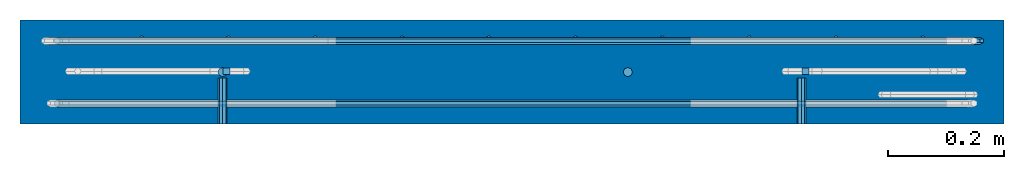
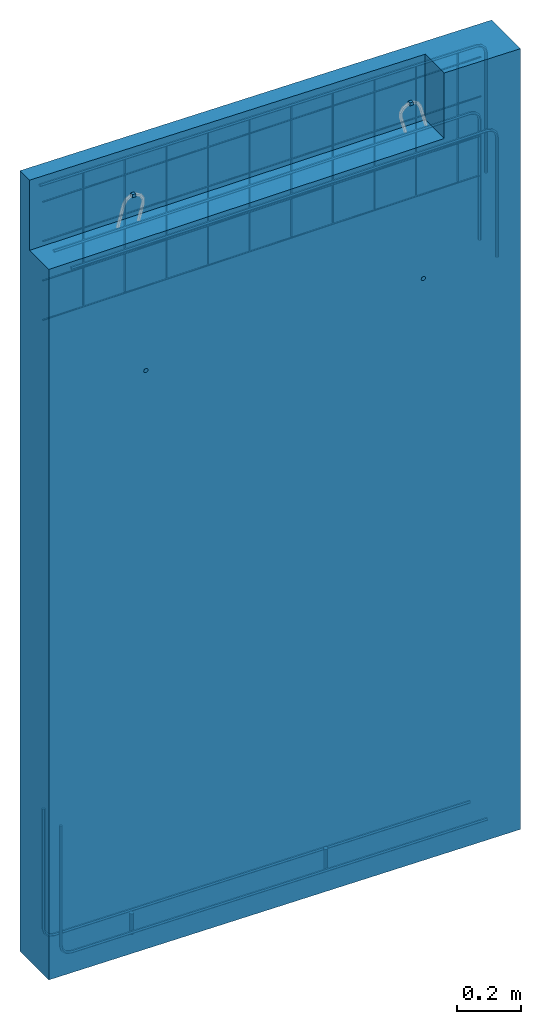
# One storey, part 1 of 3: 6 beams, 4 reinforcing bars, 1 wall.
"""IFC2X3 building model written with IfcOpenShell, lengths in millimetres."""

from ifc_helpers import new_model, si_unit, frame, origin_with_axes, place, context, subcontext, project, spatial, faceted_brep, source, transform, mapped, material, type_object, element, save


model = new_model("IFC2X3")

# Units and contexts
model_context = context("Model", 3, precision=1e-05, world=origin_with_axes())
body_context = subcontext(model_context, "Body", "Model", "MODEL_VIEW")
ifc_project = project(units=[si_unit("LENGTHUNIT", "METRE", prefix="MILLI"), si_unit("AREAUNIT", "SQUARE_METRE"), si_unit("VOLUMEUNIT", "CUBIC_METRE"), si_unit("MASSUNIT", "GRAM", prefix="KILO"), si_unit("TIMEUNIT", "SECOND"), si_unit("PLANEANGLEUNIT", "RADIAN"), si_unit("SOLIDANGLEUNIT", "STERADIAN"), si_unit("THERMODYNAMICTEMPERATUREUNIT", "DEGREE_CELSIUS"), si_unit("LUMINOUSINTENSITYUNIT", "LUMEN")], contexts=[model_context])

# Site, building, storey
site_placement = place(None, origin_with_axes())
site = spatial("IfcSite", under=ifc_project, at=site_placement, CompositionType="ELEMENT")
building_placement = place(site_placement, origin_with_axes())
building = spatial("IfcBuilding", under=site, at=building_placement, Name="Undefined", CompositionType="ELEMENT")
storey_placement = place(building_placement, origin_with_axes())
storey = spatial("IfcBuildingStorey", under=building, at=storey_placement, Name="Undefined", CompositionType="ELEMENT", Elevation=0.0)

# Beams
ifc_material_1 = material(Name="STEEL/Steel_Undefined")
beam_type_1 = type_object("IfcBeamType", Name="D16", PredefinedType="NOTDEFINED")
for number, where, z_axis, x_axis, name in (
    (1, (350.057217246016, 0.0346569152604559, -2.46430431616318e-06), (-1.9400001925155e-05, -0.99999999923382, -3.40000033739502e-05), (2.84000028124163e-05, -3.40000033666368e-05, 0.99999999901872), "M16"),
    (2, (1050.08669594096, 0.0127059129733595, 0.748830884854215), (-1.9400001925155e-05, -0.99999999923382, -3.40000033739502e-05), (2.84000028124163e-05, -3.40000033666368e-05, 0.99999999901872), "M16"),
):
    element("IfcBeam", number, at=place(storey_placement, frame(where, z_axis=z_axis, x_axis=x_axis)), inside=storey, type_object=beam_type_1, material=ifc_material_1, Name=name, ObjectType="D16", context=body_context, shape_type="Brep", body=[
        faceted_brep([(0.0, -8.0, 0.0), (-3.11670103440853e-09, -5.65685424949237, -5.65685424949238), (79.9999128622613, -5.65685424949231, -5.65685424949238), (79.999912865378, -8.0, 0.0), (-4.40768087132948e-09, 0.0, -8.0), (79.9999128609703, 0.0, -8.0), (-3.11670103614325e-09, 5.65685424949237, -5.65685424949238), (79.9999128622613, 5.65685424949237, -5.65685424949238), (1.73472347597681e-18, 7.99999999999994, 9.78384040450919e-16), (79.999912865378, 7.99999999999994, 9.78384040450919e-16), (3.11670103614325e-09, 5.65685424949237, 5.65685424949238), (79.9999128684947, 5.65685424949237, 5.65685424949238), (4.40768087479892e-09, 0.0, 8.0), (79.9999128697857, -5.6843418860808e-14, 8.0), (3.11670103787798e-09, -5.65685424949243, 5.65685424949238), (79.9999128684947, -5.65685424949237, 5.65685424949238)], [[[0, 1, 2, 3]], [[1, 4, 5, 2]], [[4, 6, 7, 5]], [[6, 8, 9, 7]], [[8, 10, 11, 9]], [[10, 12, 13, 11]], [[12, 14, 15, 13]], [[14, 0, 3, 15]], [[5, 7, 9, 11, 13, 15, 3, 2]], [[14, 12, 10, 8, 6, 4, 1, 0]]]),
    ])
for number, where, z_axis, x_axis, name in (
    (3, (349.999999989523, -89.9999999965587, 2199.99999753579), (0.0, 0.0, 1.0), (0.0, 1.0, 0.0), "M16"),
    (4, (1349.99975334186, -89.9999999756695, 2199.99999753581), (0.0, 0.0, 1.0), (0.0, 1.0, 0.0), "M16"),
):
    element("IfcBeam", number, at=place(storey_placement, frame(where, z_axis=z_axis, x_axis=x_axis)), inside=storey, type_object=beam_type_1, material=ifc_material_1, Name=name, ObjectType="D16", context=body_context, shape_type="Brep", body=[
        faceted_brep([(0.0, -8.0, 0.0), (-3.11670103440853e-09, -5.65685424949237, -5.65685424949238), (79.9999858370938, -5.65685424949237, -5.65685424949243), (79.9999858370938, -8.0, 0.0), (-4.40768087132948e-09, 0.0, -8.0), (79.9999858370938, 0.0, -8.0), (-3.11670103614325e-09, 5.65685424949237, -5.65685424949238), (79.9999858370938, 5.65685424949237, -5.65685424949243), (1.73472347597681e-18, 7.99999999999994, 9.78384040450919e-16), (79.9999858370938, 8.0, 0.0), (3.11670103614325e-09, 5.65685424949237, 5.65685424949238), (79.9999858370938, 5.65685424949237, 5.65685424949243), (4.40768087479892e-09, 0.0, 8.0), (79.9999858370938, 0.0, 8.0), (3.11670103787798e-09, -5.65685424949243, 5.65685424949238), (79.9999858370938, -5.65685424949237, 5.65685424949243)], [[[0, 1, 2, 3]], [[1, 4, 5, 2]], [[4, 6, 7, 5]], [[6, 8, 9, 7]], [[8, 10, 11, 9]], [[10, 12, 13, 11]], [[12, 14, 15, 13]], [[14, 0, 3, 15]], [[5, 7, 9, 11, 13, 15, 3, 2]], [[14, 12, 10, 8, 6, 4, 1, 0]]]),
    ])
ifc_material_2 = material()
beam_type_2 = type_object("IfcBeamType", PredefinedType="NOTDEFINED")
for number, where, z_axis, x_axis in (
    (5, (350.847429017407, 1.45757086954141, 2811.46999823785), (0.0, 0.0, 1.0), (1.0, 0.0, 0.0)),
    (6, (1362.84742901741, 1.45757086954141, 2811.46999823785), (0.0, 0.0, 1.0), (-1.0, 0.0, 0.0)),
):
    element("IfcBeam", number, at=place(storey_placement, frame(where, z_axis=z_axis, x_axis=x_axis)), inside=storey, type_object=beam_type_2, material=ifc_material_2, context=body_context, shape_type="Brep", body=[
        faceted_brep([(0.0, 6.0, -6.0), (0.0, 6.0, 6.0), (12.0, 6.0, 6.0), (12.0, 6.0, -6.0), (0.0, -6.0, 6.0), (12.0, -6.0, 6.0), (0.0, -6.0, -6.0), (12.0, -6.0, -6.0)], [[[0, 1, 2, 3]], [[1, 4, 5, 2]], [[4, 6, 7, 5]], [[6, 0, 3, 7]], [[5, 7, 3, 2]], [[6, 4, 1, 0]]]),
    ])

# Wall
ifc_material_3 = material(Name="CONCRETE/C30/37")
wall_type = type_object("IfcWallType", PredefinedType="NOTDEFINED")
wall_placement = place(storey_placement, frame((-9.94113120001435e-09, -2.55795838746404e-13, 1524.96999823788), z_axis=(0.0, 0.0, 1.0), x_axis=(1.0, 0.0, 0.0)))
element("IfcWall", 7, at=wall_placement, inside=storey, type_object=wall_type, material=ifc_material_3, context=body_context, shape_type="Brep", body=[
    faceted_brep([(1699.99987288925, -14.9999371154908, -1546.14055194714), (1.60473038835287e-22, -15.0000000154687, -1524.97000069518), (1699.99940242971, -14.9999371154908, -1524.97000070219), (1699.99939854471, 90.0000628845091, -1524.97000070219), (-2.63043434791863e-22, 90.0, -1524.97000074356), (-2.63043434791863e-22, 30.0003731013666, 1450.02983308897), (-1.78231365628939e-13, 30.0003731013666, 1182.49999999996), (1425.04640127386, 28.3311253051932, 1182.49999999996), (1425.04640127386, 28.3311253051932, 1432.28335066012), (1424.90779247491, -90.0, 1182.49999999996), (1.60473038835287e-22, -90.0, 1182.49999999996), (1.60473038835287e-22, -90.0, -1524.97000066063), (1699.99987288925, -90.0, -1546.14055191258), (1699.99987288925, -90.0, 1428.8592818923), (1424.90779247491, -90.0, 1432.28507684694), (1699.99987288925, 90.0, 1428.85928180937), (-2.63043434791863e-22, 90.0, 1450.02983306132)], [[[0, 1, 2]], [[3, 2, 1, 4]], [[5, 6, 7, 8]], [[9, 7, 6, 10]], [[10, 11, 12, 13, 14, 9]], [[8, 7, 9, 14]], [[13, 15, 16, 5, 8, 14]], [[16, 15, 3, 4]], [[11, 10, 6, 5, 16, 4, 1]], [[12, 11, 1, 0]], [[15, 13, 12, 0, 2, 3]]]),
])

# Reinforcing bars
ifc_material_4 = material(Name="A500HW")
shared_shape_1 = source(origin_with_axes(), body_context, "Body", "Brep", [
    faceted_brep([(5.19574955178955, -3.0, 0.0647039031179178), (5.19574955178955, 3.0, 0.0647039031179178), (-2.31829529531713e-16, 6.0, 0.0), (-5.19574955178955, 3.0, -0.0647039031179178), (-5.19574955178955, -3.0, -0.0647039031179178), (0.0, -6.0, 0.0), (14.4067287495791, -3.0, -1574.15162819094), (19.6024783013686, -6.0, -1574.08692428782), (14.4067287495791, 3.0, -1574.15162819094), (19.6024783013686, 6.0, -1574.08692428782), (24.7982278531582, 3.0, -1574.0222203847), (24.7982278531582, -3.0, -1574.0222203847), (20.094999676332, -3.0, -1594.53218559714), (24.5732763327458, -6.0, -1591.89684156104), (20.094999676332, 3.0, -1594.53218559714), (24.5732763327458, 6.0, -1591.89684156104), (29.0515529891596, 3.0, -1589.26149752494), (29.0515529891596, -3.0, -1589.26149752494), (35.1498779834734, -3.0, -1609.40074926283), (37.7292529758063, -6.0, -1604.89000379795), (35.1498779834734, 3.0, -1609.40074926283), (37.7292529758063, 6.0, -1604.89000379795), (40.3086279681392, 3.0, -1600.37925833307), (40.3086279681392, -3.0, -1600.37925833307), (55.5996871297744, -3.0, -1614.83479491993), (55.5996871297749, -6.0, -1609.63864249723), (55.5996871297744, 3.0, -1614.83479491993), (55.5996871297749, 6.0, -1609.63864249723), (55.5996871297755, 3.0, -1604.44249007452), (55.5996871297755, -3.0, -1604.44249007452), (514.1194664851, -3.0, -1614.83479491999), (514.1194664851, -6.0, -1609.63864249729), (514.1194664851, 3.0, -1614.83479491999), (514.1194664851, 6.0, -1609.63864249729), (514.119466485101, 3.0, -1604.44249007458), (514.119466485101, -3.0, -1604.44249007458)], [[[0, 1, 2, 3, 4, 5]], [[5, 4, 6, 7]], [[4, 3, 8, 6]], [[3, 2, 9, 8]], [[2, 1, 10, 9]], [[1, 0, 11, 10]], [[0, 5, 7, 11]], [[7, 6, 12, 13]], [[6, 8, 14, 12]], [[8, 9, 15, 14]], [[9, 10, 16, 15]], [[10, 11, 17, 16]], [[11, 7, 13, 17]], [[13, 12, 18, 19]], [[12, 14, 20, 18]], [[14, 15, 21, 20]], [[15, 16, 22, 21]], [[16, 17, 23, 22]], [[17, 13, 19, 23]], [[19, 18, 24, 25]], [[18, 20, 26, 24]], [[20, 21, 27, 26]], [[21, 22, 28, 27]], [[22, 23, 29, 28]], [[23, 19, 25, 29]], [[25, 24, 30, 31]], [[24, 26, 32, 30]], [[26, 27, 33, 32]], [[27, 28, 34, 33]], [[28, 29, 35, 34]], [[29, 25, 31, 35]], [[31, 30, 32, 33, 34, 35]]]),
])
reinforcing_bar_1_placement = place(storey_placement, frame((1699.99979999979, 90.0000000000055, 2953.82929999941), z_axis=(-1.0, 0.0, 0.0), x_axis=(0.0, 0.0, -1.0)))
element("IfcReinforcingBar", 8, at=reinforcing_bar_1_placement, inside=storey, material=ifc_material_4, Name="REBAR", BarRole="NOTDEFINED", CrossSectionArea=0.0, NominalDiameter=12.0, context=body_context, shape_type="MappedRepresentation", body=[
    mapped(shared_shape_1, transform((30.4481594376925, 36.0, 1650.63864249722))),
])
ifc_material_5 = material(Name="B500K")
shared_shape_2 = source(origin_with_axes(), body_context, "Body", "Brep", [
    faceted_brep([(3.03108891324554, 1.75, 0.0), (3.03108891324553, -1.75, 0.0), (-1.36002320516582e-15, -3.5, 0.0), (-3.03108891324554, -1.75, 0.0), (-3.03108891324554, 1.75, 0.0), (0.0, 3.5, 0.0), (-3.03108891324554, 1.75, 504.909969058717), (0.0, 3.5, 504.909969058717), (-3.03108891324554, -1.75, 504.909969058717), (-1.36002320516582e-15, -3.5, 504.909969058717), (3.03108891324553, -1.75, 504.909969058717), (3.03108891324554, 1.75, 504.909969058717)], [[[0, 1, 2, 3, 4, 5]], [[5, 4, 6, 7]], [[4, 3, 8, 6]], [[3, 2, 9, 8]], [[2, 1, 10, 9]], [[1, 0, 11, 10]], [[0, 5, 7, 11]], [[7, 6, 8, 9, 10, 11]]]),
])
shared_shape_3 = source(origin_with_axes(), body_context, "Body", "Brep", [
    faceted_brep([(3.03108891324554, 1.75, 0.0), (3.03108891324553, -1.75, 0.0), (-1.36002320516582e-15, -3.5, 0.0), (-3.03108891324554, -1.75, 0.0), (-3.03108891324554, 1.75, 0.0), (0.0, 3.5, 0.0), (-3.03108891324554, 1.75, 503.041983434955), (0.0, 3.5, 503.041983434955), (-3.03108891324554, -1.75, 503.041983434955), (-1.36002320516582e-15, -3.5, 503.041983434955), (3.03108891324553, -1.75, 503.041983434955), (3.03108891324554, 1.75, 503.041983434955)], [[[0, 1, 2, 3, 4, 5]], [[5, 4, 6, 7]], [[4, 3, 8, 6]], [[3, 2, 9, 8]], [[2, 1, 10, 9]], [[1, 0, 11, 10]], [[0, 5, 7, 11]], [[7, 6, 8, 9, 10, 11]]]),
])
shared_shape_4 = source(origin_with_axes(), body_context, "Body", "Brep", [
    faceted_brep([(3.03108891324554, 1.75, 0.0), (3.03108891324553, -1.75, 0.0), (-1.36002320516582e-15, -3.5, 0.0), (-3.03108891324554, -1.75, 0.0), (-3.03108891324554, 1.75, 0.0), (0.0, 3.5, 0.0), (-3.03108891324554, 1.75, 501.173997811192), (0.0, 3.5, 501.173997811192), (-3.03108891324554, -1.75, 501.173997811192), (-1.36002320516582e-15, -3.5, 501.173997811192), (3.03108891324553, -1.75, 501.173997811192), (3.03108891324554, 1.75, 501.173997811192)], [[[0, 1, 2, 3, 4, 5]], [[5, 4, 6, 7]], [[4, 3, 8, 6]], [[3, 2, 9, 8]], [[2, 1, 10, 9]], [[1, 0, 11, 10]], [[0, 5, 7, 11]], [[7, 6, 8, 9, 10, 11]]]),
])
shared_shape_5 = source(origin_with_axes(), body_context, "Body", "Brep", [
    faceted_brep([(3.03108891324554, 1.75, 0.0), (3.03108891324553, -1.75, 0.0), (-1.36002320516582e-15, -3.5, 0.0), (-3.03108891324554, -1.75, 0.0), (-3.03108891324554, 1.75, 0.0), (0.0, 3.5, 0.0), (-3.03108891324554, 1.75, 499.30601218743), (0.0, 3.5, 499.30601218743), (-3.03108891324554, -1.75, 499.30601218743), (-1.36002320516582e-15, -3.5, 499.30601218743), (3.03108891324553, -1.75, 499.30601218743), (3.03108891324554, 1.75, 499.30601218743)], [[[0, 1, 2, 3, 4, 5]], [[5, 4, 6, 7]], [[4, 3, 8, 6]], [[3, 2, 9, 8]], [[2, 1, 10, 9]], [[1, 0, 11, 10]], [[0, 5, 7, 11]], [[7, 6, 8, 9, 10, 11]]]),
])
shared_shape_6 = source(origin_with_axes(), body_context, "Body", "Brep", [
    faceted_brep([(3.03108891324554, 1.75, 0.0), (3.03108891324553, -1.75, 0.0), (-1.36002320516582e-15, -3.5, 0.0), (-3.03108891324554, -1.75, 0.0), (-3.03108891324554, 1.75, 0.0), (0.0, 3.5, 0.0), (-3.03108891324554, 1.75, 497.438026563668), (0.0, 3.5, 497.438026563668), (-3.03108891324554, -1.75, 497.438026563668), (-1.36002320516582e-15, -3.5, 497.438026563668), (3.03108891324553, -1.75, 497.438026563668), (3.03108891324554, 1.75, 497.438026563668)], [[[0, 1, 2, 3, 4, 5]], [[5, 4, 6, 7]], [[4, 3, 8, 6]], [[3, 2, 9, 8]], [[2, 1, 10, 9]], [[1, 0, 11, 10]], [[0, 5, 7, 11]], [[7, 6, 8, 9, 10, 11]]]),
])
shared_shape_7 = source(origin_with_axes(), body_context, "Body", "Brep", [
    faceted_brep([(3.03108891324554, 1.75, 0.0), (3.03108891324553, -1.75, 0.0), (-1.36002320516582e-15, -3.5, 0.0), (-3.03108891324554, -1.75, 0.0), (-3.03108891324554, 1.75, 0.0), (0.0, 3.5, 0.0), (-3.03108891324554, 1.75, 495.570040939906), (0.0, 3.5, 495.570040939906), (-3.03108891324554, -1.75, 495.570040939906), (-1.36002320516582e-15, -3.5, 495.570040939906), (3.03108891324553, -1.75, 495.570040939906), (3.03108891324554, 1.75, 495.570040939906)], [[[0, 1, 2, 3, 4, 5]], [[5, 4, 6, 7]], [[4, 3, 8, 6]], [[3, 2, 9, 8]], [[2, 1, 10, 9]], [[1, 0, 11, 10]], [[0, 5, 7, 11]], [[7, 6, 8, 9, 10, 11]]]),
])
shared_shape_8 = source(origin_with_axes(), body_context, "Body", "Brep", [
    faceted_brep([(3.03108891324554, 1.75, 0.0), (3.03108891324553, -1.75, 0.0), (-1.36002320516582e-15, -3.5, 0.0), (-3.03108891324554, -1.75, 0.0), (-3.03108891324554, 1.75, 0.0), (0.0, 3.5, 0.0), (-3.03108891324554, 1.75, 493.702055316143), (0.0, 3.5, 493.702055316143), (-3.03108891324554, -1.75, 493.702055316143), (-1.36002320516582e-15, -3.5, 493.702055316143), (3.03108891324553, -1.75, 493.702055316143), (3.03108891324554, 1.75, 493.702055316143)], [[[0, 1, 2, 3, 4, 5]], [[5, 4, 6, 7]], [[4, 3, 8, 6]], [[3, 2, 9, 8]], [[2, 1, 10, 9]], [[1, 0, 11, 10]], [[0, 5, 7, 11]], [[7, 6, 8, 9, 10, 11]]]),
])
shared_shape_9 = source(origin_with_axes(), body_context, "Body", "Brep", [
    faceted_brep([(3.03108891324554, 1.75, 0.0), (3.03108891324553, -1.75, 0.0), (-1.36002320516582e-15, -3.5, 0.0), (-3.03108891324554, -1.75, 0.0), (-3.03108891324554, 1.75, 0.0), (0.0, 3.5, 0.0), (-3.03108891324554, 1.75, 491.834069692381), (0.0, 3.5, 491.834069692381), (-3.03108891324554, -1.75, 491.834069692381), (-1.36002320516582e-15, -3.5, 491.834069692381), (3.03108891324553, -1.75, 491.834069692381), (3.03108891324554, 1.75, 491.834069692381)], [[[0, 1, 2, 3, 4, 5]], [[5, 4, 6, 7]], [[4, 3, 8, 6]], [[3, 2, 9, 8]], [[2, 1, 10, 9]], [[1, 0, 11, 10]], [[0, 5, 7, 11]], [[7, 6, 8, 9, 10, 11]]]),
])
shared_shape_10 = source(origin_with_axes(), body_context, "Body", "Brep", [
    faceted_brep([(3.03108891324554, 1.75, 0.0), (3.03108891324553, -1.75, 0.0), (-1.36002320516582e-15, -3.5, 0.0), (-3.03108891324554, -1.75, 0.0), (-3.03108891324554, 1.75, 0.0), (0.0, 3.5, 0.0), (-3.03108891324554, 1.75, 489.966084068619), (0.0, 3.5, 489.966084068619), (-3.03108891324554, -1.75, 489.966084068619), (-1.36002320516582e-15, -3.5, 489.966084068619), (3.03108891324553, -1.75, 489.966084068619), (3.03108891324554, 1.75, 489.966084068619)], [[[0, 1, 2, 3, 4, 5]], [[5, 4, 6, 7]], [[4, 3, 8, 6]], [[3, 2, 9, 8]], [[2, 1, 10, 9]], [[1, 0, 11, 10]], [[0, 5, 7, 11]], [[7, 6, 8, 9, 10, 11]]]),
])
shared_shape_11 = source(origin_with_axes(), body_context, "Body", "Brep", [
    faceted_brep([(3.03108891324554, 1.75, 0.0), (3.03108891324553, -1.75, 0.0), (-1.36002320516582e-15, -3.5, 0.0), (-3.03108891324554, -1.75, 0.0), (-3.03108891324554, 1.75, 0.0), (0.0, 3.5, 0.0), (-3.03108891324554, 1.75, 488.098098444857), (0.0, 3.5, 488.098098444857), (-3.03108891324554, -1.75, 488.098098444857), (-1.36002320516582e-15, -3.5, 488.098098444857), (3.03108891324553, -1.75, 488.098098444857), (3.03108891324554, 1.75, 488.098098444857)], [[[0, 1, 2, 3, 4, 5]], [[5, 4, 6, 7]], [[4, 3, 8, 6]], [[3, 2, 9, 8]], [[2, 1, 10, 9]], [[1, 0, 11, 10]], [[0, 5, 7, 11]], [[7, 6, 8, 9, 10, 11]]]),
])
shared_shape_12 = source(origin_with_axes(), body_context, "Body", "Brep", [
    faceted_brep([(0.0, 3.03108891324554, 1.75), (0.0, 3.03108891324553, -1.75), (0.0, -1.36002320516582e-15, -3.5), (0.0, -3.03108891324554, -1.75), (0.0, -3.03108891324554, 1.75), (0.0, 0.0, 3.5), (1579.9998, -3.03108891324554, 1.75), (1579.9998, 0.0, 3.5), (1579.9998, -3.03108891324554, -1.75), (1579.9998, -1.36002320516582e-15, -3.5), (1579.9998, 3.03108891324553, -1.75), (1579.9998, 3.03108891324554, 1.75)], [[[0, 1, 2, 3, 4, 5]], [[5, 4, 6, 7]], [[4, 3, 8, 6]], [[3, 2, 9, 8]], [[2, 1, 10, 9]], [[1, 0, 11, 10]], [[0, 5, 7, 11]], [[7, 6, 8, 9, 10, 11]]]),
])
shared_shape_13 = source(origin_with_axes(), body_context, "Body", "Brep", [
    faceted_brep([(0.0, 3.03108891324554, 1.75), (0.0, 3.03108891324553, -1.75), (0.0, -1.36002320516582e-15, -3.5), (0.0, -3.03108891324554, -1.75), (0.0, -3.03108891324554, 1.75), (0.0, 0.0, 3.5), (1579.9998, -3.03108891324554, 1.75), (1579.9998, 0.0, 3.5), (1579.9998, -3.03108891324554, -1.75), (1579.9998, -1.36002320516582e-15, -3.5), (1579.9998, 3.03108891324553, -1.75), (1579.9998, 3.03108891324554, 1.75)], [[[0, 1, 2, 3, 4, 5]], [[5, 4, 6, 7]], [[4, 3, 8, 6]], [[3, 2, 9, 8]], [[2, 1, 10, 9]], [[1, 0, 11, 10]], [[0, 5, 7, 11]], [[7, 6, 8, 9, 10, 11]]]),
])
shared_shape_14 = source(origin_with_axes(), body_context, "Body", "Brep", [
    faceted_brep([(0.0, 3.03108891324554, 1.75), (0.0, 3.03108891324553, -1.75), (0.0, -1.36002320516582e-15, -3.5), (0.0, -3.03108891324554, -1.75), (0.0, -3.03108891324554, 1.75), (0.0, 0.0, 3.5), (1579.99974713934, -3.03108891324554, 1.75), (1579.99974713934, 0.0, 3.5), (1579.99974713934, -3.03108891324554, -1.75), (1579.99974713934, -1.36002320516582e-15, -3.5), (1579.99974713934, 3.03108891324553, -1.75), (1579.99974713934, 3.03108891324554, 1.75)], [[[0, 1, 2, 3, 4, 5]], [[5, 4, 6, 7]], [[4, 3, 8, 6]], [[3, 2, 9, 8]], [[2, 1, 10, 9]], [[1, 0, 11, 10]], [[0, 5, 7, 11]], [[7, 6, 8, 9, 10, 11]]]),
])
shared_shape_15 = source(origin_with_axes(), body_context, "Body", "Brep", [
    faceted_brep([(0.0, 3.03108891324554, 1.75), (0.0, 3.03108891324553, -1.75), (0.0, -1.36002320516582e-15, -3.5), (0.0, -3.03108891324554, -1.75), (0.0, -3.03108891324554, 1.75), (0.0, 0.0, 3.5), (1579.99974713934, -3.03108891324554, 1.75), (1579.99974713934, 0.0, 3.5), (1579.99974713934, -3.03108891324554, -1.75), (1579.99974713934, -1.36002320516582e-15, -3.5), (1579.99974713934, 3.03108891324553, -1.75), (1579.99974713934, 3.03108891324554, 1.75)], [[[0, 1, 2, 3, 4, 5]], [[5, 4, 6, 7]], [[4, 3, 8, 6]], [[3, 2, 9, 8]], [[2, 1, 10, 9]], [[1, 0, 11, 10]], [[0, 5, 7, 11]], [[7, 6, 8, 9, 10, 11]]]),
])
reinforcing_bar_2_placement = place(storey_placement, frame((-7.13706373062981e-21, 90.0, 2407.47), z_axis=(0.0, 0.0, 1.0), x_axis=(1.0, 0.0, 0.0)))
element("IfcReinforcingBar", 9, at=reinforcing_bar_2_placement, inside=storey, material=ifc_material_5, BarRole="NOTDEFINED", CrossSectionArea=0.0, NominalDiameter=7.0, context=body_context, shape_type="MappedRepresentation", body=[
    mapped(shared_shape_2, transform((210.000000000001, -30.5, 2.63753463514149e-11))),
    mapped(shared_shape_3, transform((360.000000000001, -30.5, 4.54747350886464e-11))),
    mapped(shared_shape_4, transform((510.000000000001, -30.5, 6.41193764749914e-11))),
    mapped(shared_shape_5, transform((660.000000000001, -30.5, 8.32187652122229e-11))),
    mapped(shared_shape_6, transform((810.000000000001, -30.5, 1.01863406598568e-10))),
    mapped(shared_shape_7, transform((960.000000000001, -30.5, 1.20962795335799e-10))),
    mapped(shared_shape_8, transform((1110.0, -30.5, 1.40062184073031e-10))),
    mapped(shared_shape_9, transform((1260.0, -30.5, 1.58706825459376e-10))),
    mapped(shared_shape_10, transform((1410.0, -30.5, 1.77806214196607e-10))),
    mapped(shared_shape_11, transform((1560.0, -30.5, 1.96450855582953e-10))),
    mapped(shared_shape_12, transform((60.0000000000009, -37.5, 7.73070496506989e-12))),
    mapped(shared_shape_13, transform((60.000026430244, -37.5, 150.000000000008))),
    mapped(shared_shape_14, transform((60.000052860487, -37.5, 300.000000000008))),
    mapped(shared_shape_15, transform((60.0000792907301, -37.5, 450.000000000008))),
])
shared_shape_16 = source(origin_with_axes(), body_context, "Body", "Brep", [
    faceted_brep([(5.19574955178955, -3.0, 0.0647039031179178), (5.19574955178955, 3.0, 0.0647039031179178), (-2.31829529531713e-16, 6.0, 0.0), (-5.19574955178955, 3.0, -0.0647039031179178), (-5.19574955178955, -3.0, -0.0647039031179178), (0.0, -6.0, 0.0), (13.4979339843204, -3.00000000000001, -1501.1678627136), (18.693683532257, -6.00000000000001, -1501.1031585011), (13.4979339843204, 2.99999999999999, -1501.1678627136), (18.693683532257, 5.99999999999999, -1501.1031585011), (23.8894330801937, 2.99999999999999, -1501.03845428859), (23.8894330801937, -3.00000000000002, -1501.03845428859), (19.1862057099525, -3.00000000000001, -1521.54841907636), (23.6644822617492, -6.00000000000001, -1518.91307486248), (19.1862057099525, 2.99999999999999, -1521.54841907636), (23.6644822617492, 5.99999999999999, -1518.91307486248), (28.142758813546, 2.99999999999999, -1516.2777306486), (28.142758813546, -3.00000000000002, -1516.2777306486), (34.2410838975071, -3.00000000000001, -1536.41698173851), (36.8204588003068, -6.00000000000001, -1531.90623622243), (34.2410838975071, 2.99999999999999, -1536.41698173851), (36.8204588003068, 5.99999999999999, -1531.90623622243), (39.3998337031064, 2.99999999999999, -1527.39549070635), (39.3998337031064, -3.00000000000002, -1527.39549070635), (54.6908923339742, -3.00000000000001, -1541.8510269897), (54.6908923339743, -6.00000000000001, -1536.654874567), (54.6908923339742, 2.99999999999999, -1541.8510269897), (54.6908923339743, 5.99999999999999, -1536.654874567), (54.6908923339744, 2.99999999999999, -1531.45872214429), (54.6908923339744, -3.00000000000002, -1531.45872214429), (513.210674159488, -3.00000000000001, -1541.8510269897), (513.210674159488, -6.00000000000001, -1536.654874567), (513.210674159488, 2.99999999999999, -1541.8510269897), (513.210674159488, 5.99999999999999, -1536.654874567), (513.210674159488, 2.99999999999999, -1531.45872214429), (513.210674159488, -3.00000000000002, -1531.45872214429)], [[[0, 1, 2, 3, 4, 5]], [[5, 4, 6, 7]], [[4, 3, 8, 6]], [[3, 2, 9, 8]], [[2, 1, 10, 9]], [[1, 0, 11, 10]], [[0, 5, 7, 11]], [[7, 6, 12, 13]], [[6, 8, 14, 12]], [[8, 9, 15, 14]], [[9, 10, 16, 15]], [[10, 11, 17, 16]], [[11, 7, 13, 17]], [[13, 12, 18, 19]], [[12, 14, 20, 18]], [[14, 15, 21, 20]], [[15, 16, 22, 21]], [[16, 17, 23, 22]], [[17, 13, 19, 23]], [[19, 18, 24, 25]], [[18, 20, 26, 24]], [[20, 21, 27, 26]], [[21, 22, 28, 27]], [[22, 23, 29, 28]], [[23, 19, 25, 29]], [[25, 24, 30, 31]], [[24, 26, 32, 30]], [[26, 27, 33, 32]], [[27, 28, 34, 33]], [[28, 29, 35, 34]], [[29, 25, 31, 35]], [[31, 30, 32, 33, 34, 35]]]),
])
shared_shape_17 = source(origin_with_axes(), body_context, "Body", "Brep", [
    faceted_brep([(5.19574955178955, -3.0, 0.0647039031179178), (5.19574955178955, 3.0, 0.0647039031179178), (-2.31829529531713e-16, 6.0, 0.0), (-5.19574955178955, 3.0, -0.0647039031179178), (-5.19574955178955, -3.0, -0.0647039031179178), (0.0, -6.0, 0.0), (13.4979339843204, -3.00000000000001, -1501.1678627136), (18.693683532257, -6.00000000000001, -1501.1031585011), (13.4979339843204, 2.99999999999999, -1501.1678627136), (18.693683532257, 5.99999999999999, -1501.1031585011), (23.8894330801937, 2.99999999999999, -1501.03845428859), (23.8894330801937, -3.00000000000002, -1501.03845428859), (19.1862057099525, -3.00000000000001, -1521.54841907636), (23.6644822617492, -6.00000000000001, -1518.91307486248), (19.1862057099525, 2.99999999999999, -1521.54841907636), (23.6644822617492, 5.99999999999999, -1518.91307486248), (28.142758813546, 2.99999999999999, -1516.2777306486), (28.142758813546, -3.00000000000002, -1516.2777306486), (34.2410838975071, -3.00000000000001, -1536.41698173851), (36.8204588003068, -6.00000000000001, -1531.90623622243), (34.2410838975071, 2.99999999999999, -1536.41698173851), (36.8204588003068, 5.99999999999999, -1531.90623622243), (39.3998337031064, 2.99999999999999, -1527.39549070635), (39.3998337031064, -3.00000000000002, -1527.39549070635), (54.6908923339742, -3.00000000000001, -1541.8510269897), (54.6908923339743, -6.00000000000001, -1536.654874567), (54.6908923339742, 2.99999999999999, -1541.8510269897), (54.6908923339743, 5.99999999999999, -1536.654874567), (54.6908923339744, 2.99999999999999, -1531.45872214429), (54.6908923339744, -3.00000000000002, -1531.45872214429), (513.210674159488, -3.00000000000001, -1541.8510269897), (513.210674159488, -6.00000000000001, -1536.654874567), (513.210674159488, 2.99999999999999, -1541.8510269897), (513.210674159488, 5.99999999999999, -1536.654874567), (513.210674159488, 2.99999999999999, -1531.45872214429), (513.210674159488, -3.00000000000002, -1531.45872214429)], [[[0, 1, 2, 3, 4, 5]], [[5, 4, 6, 7]], [[4, 3, 8, 6]], [[3, 2, 9, 8]], [[2, 1, 10, 9]], [[1, 0, 11, 10]], [[0, 5, 7, 11]], [[7, 6, 12, 13]], [[6, 8, 14, 12]], [[8, 9, 15, 14]], [[9, 10, 16, 15]], [[10, 11, 17, 16]], [[11, 7, 13, 17]], [[13, 12, 18, 19]], [[12, 14, 20, 18]], [[14, 15, 21, 20]], [[15, 16, 22, 21]], [[16, 17, 23, 22]], [[17, 13, 19, 23]], [[19, 18, 24, 25]], [[18, 20, 26, 24]], [[20, 21, 27, 26]], [[21, 22, 28, 27]], [[22, 23, 29, 28]], [[23, 19, 25, 29]], [[25, 24, 30, 31]], [[24, 26, 32, 30]], [[26, 27, 33, 32]], [[27, 28, 34, 33]], [[28, 29, 35, 34]], [[29, 25, 31, 35]], [[31, 30, 32, 33, 34, 35]]]),
])
reinforcing_bar_3_placement = place(storey_placement, frame((-8.63565219333395e-10, 90.0000000001215, 5.35038680027355e-12), z_axis=(1.0, 0.0, 0.0), x_axis=(0.0, 0.0, 1.0)))
element("IfcReinforcingBar", 10, at=reinforcing_bar_3_placement, inside=storey, material=ifc_material_4, Name="REBAR", BarRole="NOTDEFINED", CrossSectionArea=0.0, NominalDiameter=12.0, context=body_context, shape_type="MappedRepresentation", body=[
    mapped(shared_shape_16, transform((32.0706014194239, 36.0, 1600.654874567))),
    mapped(shared_shape_17, transform((32.0706014194261, 143.999999980391, 1600.65487456699))),
])
shared_shape_18 = source(origin_with_axes(), body_context, "Body", "Brep", [
    faceted_brep([(5.19615242270663, -3.0, -2.7989164715733e-08), (5.19615242270663, 3.0, -2.79885667768579e-08), (-2.31829529531713e-16, 6.0, 0.0), (-5.19615242270663, 3.0, 2.7989164715733e-08), (-5.19615242270663, -3.0, 2.79885667768579e-08), (0.0, -6.0, 0.0), (-5.19616050239281, -2.99999999985052, -1499.99936799093), (-8.07968618232735e-06, -5.99999999985052, -1499.99936801892), (-5.19616050239282, 3.00000000014948, -1499.99936799093), (-8.07968618458343e-06, 6.00000000014948, -1499.99936801892), (5.19614434302045, 3.00000000014949, -1499.99936804691), (5.19614434302045, -2.99999999985051, -1499.99936804691), (0.323077310106932, -2.99999999984846, -1520.59744429607), (4.8230773194366, -5.99999999984872, -1517.99936810088), (0.323077310106889, 3.00000000015154, -1520.59744429607), (4.82307731943651, 6.00000000015128, -1517.99936810088), (9.32307732876617, 3.00000000015103, -1515.40129190568), (9.32307732876621, -2.99999999984897, -1515.40129190568), (15.4019156449031, -2.99999999984694, -1535.67628271209), (17.9999918643362, -5.99999999984739, -1531.17628271675), (15.4019156449031, 3.00000000015306, -1535.67628271209), (17.9999918643361, 6.00000000015261, -1531.17628271675), (20.5980680837692, 3.00000000015216, -1526.67628272142), (20.5980680837692, -2.99999999984784, -1526.67628272142), (35.9999919203139, -2.99999999984637, -1541.19552063554), (35.999991920314, -5.99999999984689, -1535.99936821283), (35.9999919203138, 3.00000000015363, -1541.19552063554), (35.9999919203138, 6.00000000015311, -1535.99936821283), (35.9999919203139, 3.00000000015259, -1530.80321579013), (35.999991920314, -2.99999999984741, -1530.80321579013), (493.999991694083, -2.99999999984593, -1541.19552063554), (493.999991694083, -5.99999999984645, -1535.99936821283), (493.999991694082, 3.00000000015407, -1541.19552063554), (493.999991694082, 6.00000000015355, -1535.99936821283), (493.999991694083, 3.00000000015303, -1530.80321579013), (493.999991694083, -2.99999999984697, -1530.80321579013)], [[[0, 1, 2, 3, 4, 5]], [[5, 4, 6, 7]], [[4, 3, 8, 6]], [[3, 2, 9, 8]], [[2, 1, 10, 9]], [[1, 0, 11, 10]], [[0, 5, 7, 11]], [[7, 6, 12, 13]], [[6, 8, 14, 12]], [[8, 9, 15, 14]], [[9, 10, 16, 15]], [[10, 11, 17, 16]], [[11, 7, 13, 17]], [[13, 12, 18, 19]], [[12, 14, 20, 18]], [[14, 15, 21, 20]], [[15, 16, 22, 21]], [[16, 17, 23, 22]], [[17, 13, 19, 23]], [[19, 18, 24, 25]], [[18, 20, 26, 24]], [[20, 21, 27, 26]], [[21, 22, 28, 27]], [[22, 23, 29, 28]], [[23, 19, 25, 29]], [[25, 24, 30, 31]], [[24, 26, 32, 30]], [[26, 27, 33, 32]], [[27, 28, 34, 33]], [[28, 29, 35, 34]], [[29, 25, 31, 35]], [[31, 30, 32, 33, 34, 35]]]),
])
shared_shape_19 = source(origin_with_axes(), body_context, "Body", "Brep", [
    faceted_brep([(5.19615242270663, -3.0, -2.7989164715733e-08), (5.19615242270663, 3.0, -2.79885667768579e-08), (-2.31829529531713e-16, 6.0, 0.0), (-5.19615242270663, 3.0, 2.7989164715733e-08), (-5.19615242270663, -3.0, 2.79885667768579e-08), (0.0, -6.0, 0.0), (-5.19616050239281, -2.99999999985052, -1499.99936799093), (-8.07968618232735e-06, -5.99999999985052, -1499.99936801892), (-5.19616050239282, 3.00000000014948, -1499.99936799093), (-8.07968618458343e-06, 6.00000000014948, -1499.99936801892), (5.19614434302045, 3.00000000014949, -1499.99936804691), (5.19614434302045, -2.99999999985051, -1499.99936804691), (0.323077310106932, -2.99999999984846, -1520.59744429607), (4.8230773194366, -5.99999999984872, -1517.99936810088), (0.323077310106889, 3.00000000015154, -1520.59744429607), (4.82307731943651, 6.00000000015128, -1517.99936810088), (9.32307732876617, 3.00000000015103, -1515.40129190568), (9.32307732876621, -2.99999999984897, -1515.40129190568), (15.4019156449031, -2.99999999984694, -1535.67628271209), (17.9999918643362, -5.99999999984739, -1531.17628271675), (15.4019156449031, 3.00000000015306, -1535.67628271209), (17.9999918643361, 6.00000000015261, -1531.17628271675), (20.5980680837692, 3.00000000015216, -1526.67628272142), (20.5980680837692, -2.99999999984784, -1526.67628272142), (35.9999919203139, -2.99999999984637, -1541.19552063554), (35.999991920314, -5.99999999984689, -1535.99936821283), (35.9999919203138, 3.00000000015363, -1541.19552063554), (35.9999919203138, 6.00000000015311, -1535.99936821283), (35.9999919203139, 3.00000000015259, -1530.80321579013), (35.999991920314, -2.99999999984741, -1530.80321579013), (493.999991694083, -2.99999999984593, -1541.19552063554), (493.999991694083, -5.99999999984645, -1535.99936821283), (493.999991694082, 3.00000000015407, -1541.19552063554), (493.999991694082, 6.00000000015355, -1535.99936821283), (493.999991694083, 3.00000000015303, -1530.80321579013), (493.999991694083, -2.99999999984697, -1530.80321579013)], [[[0, 1, 2, 3, 4, 5]], [[5, 4, 6, 7]], [[4, 3, 8, 6]], [[3, 2, 9, 8]], [[2, 1, 10, 9]], [[1, 0, 11, 10]], [[0, 5, 7, 11]], [[7, 6, 12, 13]], [[6, 8, 14, 12]], [[8, 9, 15, 14]], [[9, 10, 16, 15]], [[10, 11, 17, 16]], [[11, 7, 13, 17]], [[13, 12, 18, 19]], [[12, 14, 20, 18]], [[14, 15, 21, 20]], [[15, 16, 22, 21]], [[16, 17, 23, 22]], [[17, 13, 19, 23]], [[19, 18, 24, 25]], [[18, 20, 26, 24]], [[20, 21, 27, 26]], [[21, 22, 28, 27]], [[22, 23, 29, 28]], [[23, 19, 25, 29]], [[25, 24, 30, 31]], [[24, 26, 32, 30]], [[26, 27, 33, 32]], [[27, 28, 34, 33]], [[28, 29, 35, 34]], [[29, 25, 31, 35]], [[31, 30, 32, 33, 34, 35]]]),
])
reinforcing_bar_4_placement = place(storey_placement, frame((1699.99936849263, 89.9999999999291, 2707.47000915697), z_axis=(-1.0, 0.0, 0.0), x_axis=(0.0, 0.0, -1.0)))
element("IfcReinforcingBar", 11, at=reinforcing_bar_4_placement, inside=storey, material=ifc_material_4, Name="REBAR", BarRole="NOTDEFINED", CrossSectionArea=0.0, NominalDiameter=12.0, context=body_context, shape_type="MappedRepresentation", body=[
    mapped(shared_shape_18, transform((52.0000086183318, 35.9999999998406, 1599.99936821283))),
    mapped(shared_shape_19, transform((52.0000086183313, 143.999999980232, 1599.99936821284))),
])

save(model, "model.ifc")
